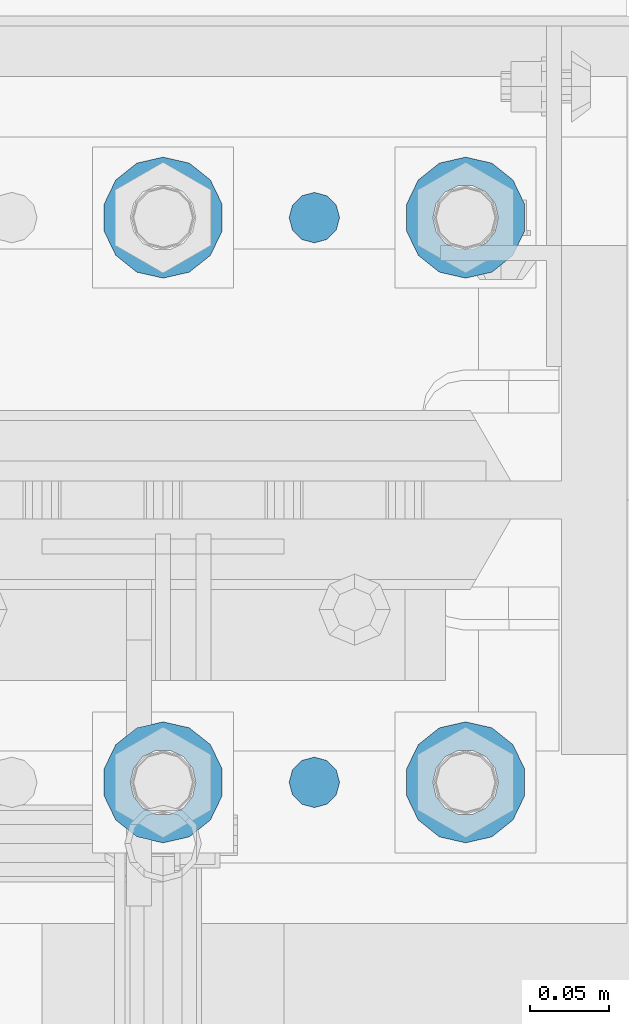
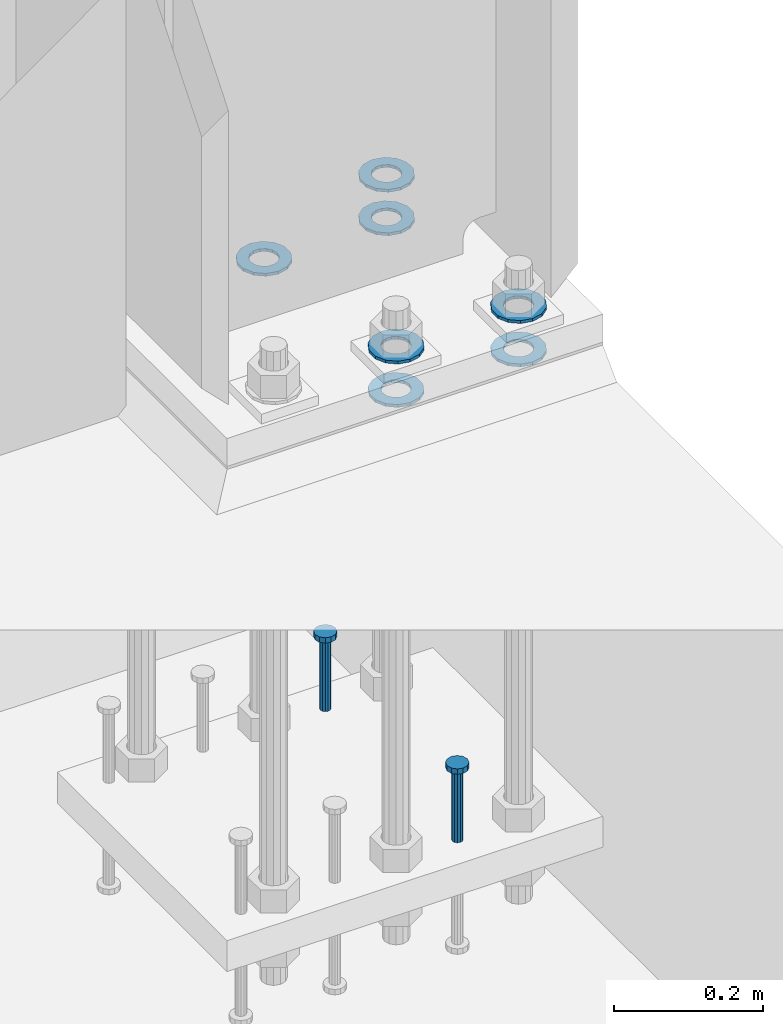
# One storey, part 859 of 1876: 9 columns, 1 element without a shape of its own.
"""IFC2X3 building model written with IfcOpenShell, lengths in millimetres."""

from ifc_helpers import new_model, si_unit, frame, origin_with_axes, place, context, subcontext, project, spatial, faceted_brep, material, type_object, element, aggregate, save


model = new_model("IFC2X3")

# Units and contexts
model_context = context("Model", 3, precision=1e-05, world=origin_with_axes())
body_context = subcontext(model_context, "Body", "Model", "MODEL_VIEW")
ifc_project = project(units=[si_unit("LENGTHUNIT", "METRE", prefix="MILLI"), si_unit("AREAUNIT", "SQUARE_METRE"), si_unit("VOLUMEUNIT", "CUBIC_METRE"), si_unit("MASSUNIT", "GRAM", prefix="KILO"), si_unit("TIMEUNIT", "SECOND"), si_unit("PLANEANGLEUNIT", "RADIAN"), si_unit("SOLIDANGLEUNIT", "STERADIAN"), si_unit("THERMODYNAMICTEMPERATUREUNIT", "DEGREE_CELSIUS"), si_unit("LUMINOUSINTENSITYUNIT", "LUMEN")], contexts=[model_context])

# Site, building, storey
site_placement = place(None, origin_with_axes())
site = spatial("IfcSite", under=ifc_project, at=site_placement, CompositionType="ELEMENT")
building_placement = place(site_placement, origin_with_axes())
building = spatial("IfcBuilding", under=site, at=building_placement, Name="Undefined", CompositionType="ELEMENT")
storey_placement = place(building_placement, origin_with_axes())
storey = spatial("IfcBuildingStorey", under=building, at=storey_placement, Name="Undefined", CompositionType="ELEMENT", Elevation=0.0)

# Assembly, columns
assembly_placement = place(storey_placement, origin_with_axes())
assembly = element("IfcElementAssembly", 1, at=assembly_placement, inside=storey, Name="TEMPLATE", AssemblyPlace="NOTDEFINED", PredefinedType="RIGID_FRAME")
ifc_material_1 = material(Name="STEEL/F436")
column_type_1 = type_object("IfcColumnType", Name="1-1/2_WASHER", PredefinedType="NOTDEFINED")
column_1_placement = place(assembly_placement, frame((7810.5, 13538.2, 38.1), z_axis=(1.0, 0.0, 0.0), x_axis=(0.0, 0.0, -1.0)))
column_1 = element("IfcColumn", 2, at=column_1_placement, type_object=column_type_1, material=ifc_material_1, Name="WASHER", ObjectType="1-1/2_WASHER", context=body_context, shape_type="Brep", body=[
    faceted_brep([(0.0, -38.0999984741211, 0.0), (0.0, -34.3269124923136, -16.5309697983251), (4.7625, -34.3269124923136, -16.5309697983251), (4.7625, -38.0999984741211, 0.0), (0.0, -23.7549604994474, -29.787778289052), (4.7625, -23.7549604994474, -29.787778289052), (0.0, -8.4780472441962, -37.1447519665058), (4.7625, -8.4780472441962, -37.1447519665058), (0.0, 8.4780472441962, -37.1447519665058), (4.7625, 8.4780472441962, -37.1447519665058), (0.0, 23.7549604994474, -29.787778289052), (4.7625, 23.7549604994474, -29.787778289052), (0.0, 34.3269124923136, -16.5309697983251), (4.7625, 34.3269124923136, -16.5309697983251), (0.0, 38.0999984741211, 0.0), (4.7625, 38.0999984741211, 0.0), (0.0, 34.3269124923136, 16.5309697983251), (4.7625, 34.3269124923136, 16.5309697983251), (0.0, 23.7549604994474, 29.787778289052), (4.7625, 23.7549604994474, 29.787778289052), (0.0, 8.4780472441962, 37.1447519665058), (4.7625, 8.4780472441962, 37.1447519665058), (0.0, -8.4780472441962, 37.1447519665058), (4.7625, -8.4780472441962, 37.1447519665058), (0.0, -23.7549604994474, 29.787778289052), (4.7625, -23.7549604994474, 29.787778289052), (0.0, -34.3269124923136, 16.5309697983251), (4.7625, -34.3269124923136, 16.5309697983251), (0.0, 0.0, 20.6399993896484), (0.0, 8.95536011056538, 18.5959968835978), (4.7625, 8.95536011056538, 18.595996883598), (4.7625, 0.0, 20.6399993896484), (0.0, 16.1370013209489, 12.8688291298158), (4.7625, 16.1370013209489, 12.8688291298162), (0.0, 20.1225115123834, 4.59283194104228), (4.7625, 20.1225115123834, 4.59283194104222), (0.0, 20.1225115123834, -4.59283194104228), (4.7625, 20.1225115123834, -4.59283194104242), (0.0, 16.1370013209489, -12.8688291298167), (4.7625, 16.1370013209489, -12.8688291298163), (0.0, 8.95536011056538, -18.5959968835978), (4.7625, 8.95536011056538, -18.5959968835982), (0.0, 0.0, -20.6399993896484), (4.7625, 0.0, -20.6399993896484), (0.0, -8.95536011056538, -18.5959968835978), (4.7625, -8.95536011056538, -18.595996883598), (0.0, -16.1370013209489, -12.8688291298158), (4.7625, -16.1370013209489, -12.8688291298162), (0.0, -20.1225115123834, -4.59283194104228), (4.7625, -20.1225115123834, -4.59283194104222), (0.0, -20.1225115123834, 4.59283194104228), (4.7625, -20.1225115123834, 4.59283194104242), (0.0, -16.1370013209489, 12.8688291298167), (4.7625, -16.1370013209489, 12.8688291298163), (0.0, -8.95536011056538, 18.5959968835978), (4.7625, -8.95536011056538, 18.5959968835982)], [[[0, 1, 2, 3]], [[1, 4, 5, 2]], [[4, 6, 7, 5]], [[6, 8, 9, 7]], [[8, 10, 11, 9]], [[10, 12, 13, 11]], [[12, 14, 15, 13]], [[14, 16, 17, 15]], [[16, 18, 19, 17]], [[18, 20, 21, 19]], [[20, 22, 23, 21]], [[22, 24, 25, 23]], [[24, 26, 27, 25]], [[26, 0, 3, 27]], [[28, 29, 30, 31]], [[29, 32, 33, 30]], [[32, 34, 35, 33]], [[34, 36, 37, 35]], [[36, 38, 39, 37]], [[38, 40, 41, 39]], [[40, 42, 43, 41]], [[42, 44, 45, 43]], [[44, 46, 47, 45]], [[46, 48, 49, 47]], [[48, 50, 51, 49]], [[50, 52, 53, 51]], [[52, 54, 55, 53]], [[54, 28, 31, 55]], [[5, 7, 9, 11, 13, 15, 17, 19, 21, 23, 25, 27, 3, 2], [33, 35, 37, 39, 41, 43, 45, 47, 49, 51, 53, 55, 31, 30]], [[26, 24, 22, 20, 18, 16, 14, 12, 10, 8, 6, 4, 1, 0], [54, 52, 50, 48, 46, 44, 42, 40, 38, 36, 34, 32, 29, 28]]]),
])
column_2_placement = place(assembly_placement, frame((7810.5, 13893.8, 38.1), z_axis=(-1.0, 0.0, 0.0), x_axis=(0.0, 0.0, -1.0)))
column_2 = element("IfcColumn", 3, at=column_2_placement, type_object=column_type_1, material=ifc_material_1, Name="WASHER", ObjectType="1-1/2_WASHER", context=body_context, shape_type="Brep", body=[
    faceted_brep([(0.0, -38.0999984741211, 0.0), (0.0, -34.3269124923136, -16.5309697983251), (4.7625, -34.3269124923136, -16.5309697983251), (4.7625, -38.0999984741211, 0.0), (0.0, -23.7549604994474, -29.787778289052), (4.7625, -23.7549604994474, -29.787778289052), (0.0, -8.4780472441962, -37.1447519665058), (4.7625, -8.4780472441962, -37.1447519665058), (0.0, 8.4780472441962, -37.1447519665058), (4.7625, 8.4780472441962, -37.1447519665058), (0.0, 23.7549604994474, -29.787778289052), (4.7625, 23.7549604994474, -29.787778289052), (0.0, 34.3269124923136, -16.5309697983251), (4.7625, 34.3269124923136, -16.5309697983251), (0.0, 38.0999984741211, 0.0), (4.7625, 38.0999984741211, 0.0), (0.0, 34.3269124923136, 16.5309697983251), (4.7625, 34.3269124923136, 16.5309697983251), (0.0, 23.7549604994474, 29.787778289052), (4.7625, 23.7549604994474, 29.787778289052), (0.0, 8.4780472441962, 37.1447519665058), (4.7625, 8.4780472441962, 37.1447519665058), (0.0, -8.4780472441962, 37.1447519665058), (4.7625, -8.4780472441962, 37.1447519665058), (0.0, -23.7549604994474, 29.787778289052), (4.7625, -23.7549604994474, 29.787778289052), (0.0, -34.3269124923136, 16.5309697983251), (4.7625, -34.3269124923136, 16.5309697983251), (0.0, 0.0, 20.6399993896484), (0.0, 8.95536011056538, 18.5959968835978), (4.7625, 8.95536011056538, 18.595996883598), (4.7625, 0.0, 20.6399993896484), (0.0, 16.1370013209489, 12.8688291298158), (4.7625, 16.1370013209489, 12.8688291298162), (0.0, 20.1225115123834, 4.59283194104228), (4.7625, 20.1225115123834, 4.59283194104222), (0.0, 20.1225115123834, -4.59283194104228), (4.7625, 20.1225115123834, -4.59283194104242), (0.0, 16.1370013209489, -12.8688291298167), (4.7625, 16.1370013209489, -12.8688291298163), (0.0, 8.95536011056538, -18.5959968835978), (4.7625, 8.95536011056538, -18.5959968835982), (0.0, 0.0, -20.6399993896484), (4.7625, 0.0, -20.6399993896484), (0.0, -8.95536011056538, -18.5959968835978), (4.7625, -8.95536011056538, -18.595996883598), (0.0, -16.1370013209489, -12.8688291298158), (4.7625, -16.1370013209489, -12.8688291298162), (0.0, -20.1225115123834, -4.59283194104228), (4.7625, -20.1225115123834, -4.59283194104222), (0.0, -20.1225115123834, 4.59283194104228), (4.7625, -20.1225115123834, 4.59283194104242), (0.0, -16.1370013209489, 12.8688291298167), (4.7625, -16.1370013209489, 12.8688291298163), (0.0, -8.95536011056538, 18.5959968835978), (4.7625, -8.95536011056538, 18.5959968835982)], [[[0, 1, 2, 3]], [[1, 4, 5, 2]], [[4, 6, 7, 5]], [[6, 8, 9, 7]], [[8, 10, 11, 9]], [[10, 12, 13, 11]], [[12, 14, 15, 13]], [[14, 16, 17, 15]], [[16, 18, 19, 17]], [[18, 20, 21, 19]], [[20, 22, 23, 21]], [[22, 24, 25, 23]], [[24, 26, 27, 25]], [[26, 0, 3, 27]], [[28, 29, 30, 31]], [[29, 32, 33, 30]], [[32, 34, 35, 33]], [[34, 36, 37, 35]], [[36, 38, 39, 37]], [[38, 40, 41, 39]], [[40, 42, 43, 41]], [[42, 44, 45, 43]], [[44, 46, 47, 45]], [[46, 48, 49, 47]], [[48, 50, 51, 49]], [[50, 52, 53, 51]], [[52, 54, 55, 53]], [[54, 28, 31, 55]], [[5, 7, 9, 11, 13, 15, 17, 19, 21, 23, 25, 27, 3, 2], [33, 35, 37, 39, 41, 43, 45, 47, 49, 51, 53, 55, 31, 30]], [[26, 24, 22, 20, 18, 16, 14, 12, 10, 8, 6, 4, 1, 0], [54, 52, 50, 48, 46, 44, 42, 40, 38, 36, 34, 32, 29, 28]]]),
])
column_3_placement = place(assembly_placement, frame((7620.0, 13538.2, 38.1), z_axis=(1.0, 0.0, 0.0), x_axis=(0.0, 0.0, -1.0)))
column_3 = element("IfcColumn", 4, at=column_3_placement, type_object=column_type_1, material=ifc_material_1, Name="WASHER", ObjectType="1-1/2_WASHER", context=body_context, shape_type="Brep", body=[
    faceted_brep([(0.0, -38.0999984741211, 0.0), (0.0, -34.3269124923136, -16.5309697983251), (4.7625, -34.3269124923136, -16.5309697983251), (4.7625, -38.0999984741211, 0.0), (0.0, -23.7549604994474, -29.787778289052), (4.7625, -23.7549604994474, -29.787778289052), (0.0, -8.4780472441962, -37.1447519665058), (4.7625, -8.4780472441962, -37.1447519665058), (0.0, 8.4780472441962, -37.1447519665058), (4.7625, 8.4780472441962, -37.1447519665058), (0.0, 23.7549604994474, -29.787778289052), (4.7625, 23.7549604994474, -29.787778289052), (0.0, 34.3269124923136, -16.5309697983251), (4.7625, 34.3269124923136, -16.5309697983251), (0.0, 38.0999984741211, 0.0), (4.7625, 38.0999984741211, 0.0), (0.0, 34.3269124923136, 16.5309697983251), (4.7625, 34.3269124923136, 16.5309697983251), (0.0, 23.7549604994474, 29.787778289052), (4.7625, 23.7549604994474, 29.787778289052), (0.0, 8.4780472441962, 37.1447519665058), (4.7625, 8.4780472441962, 37.1447519665058), (0.0, -8.4780472441962, 37.1447519665058), (4.7625, -8.4780472441962, 37.1447519665058), (0.0, -23.7549604994474, 29.787778289052), (4.7625, -23.7549604994474, 29.787778289052), (0.0, -34.3269124923136, 16.5309697983251), (4.7625, -34.3269124923136, 16.5309697983251), (0.0, 0.0, 20.6399993896484), (0.0, 8.95536011056538, 18.5959968835978), (4.7625, 8.95536011056538, 18.595996883598), (4.7625, 0.0, 20.6399993896484), (0.0, 16.1370013209489, 12.8688291298158), (4.7625, 16.1370013209489, 12.8688291298162), (0.0, 20.1225115123834, 4.59283194104228), (4.7625, 20.1225115123834, 4.59283194104222), (0.0, 20.1225115123834, -4.59283194104228), (4.7625, 20.1225115123834, -4.59283194104242), (0.0, 16.1370013209489, -12.8688291298167), (4.7625, 16.1370013209489, -12.8688291298163), (0.0, 8.95536011056538, -18.5959968835978), (4.7625, 8.95536011056538, -18.5959968835982), (0.0, 0.0, -20.6399993896484), (4.7625, 0.0, -20.6399993896484), (0.0, -8.95536011056538, -18.5959968835978), (4.7625, -8.95536011056538, -18.595996883598), (0.0, -16.1370013209489, -12.8688291298158), (4.7625, -16.1370013209489, -12.8688291298162), (0.0, -20.1225115123834, -4.59283194104228), (4.7625, -20.1225115123834, -4.59283194104222), (0.0, -20.1225115123834, 4.59283194104228), (4.7625, -20.1225115123834, 4.59283194104242), (0.0, -16.1370013209489, 12.8688291298167), (4.7625, -16.1370013209489, 12.8688291298163), (0.0, -8.95536011056538, 18.5959968835978), (4.7625, -8.95536011056538, 18.5959968835982)], [[[0, 1, 2, 3]], [[1, 4, 5, 2]], [[4, 6, 7, 5]], [[6, 8, 9, 7]], [[8, 10, 11, 9]], [[10, 12, 13, 11]], [[12, 14, 15, 13]], [[14, 16, 17, 15]], [[16, 18, 19, 17]], [[18, 20, 21, 19]], [[20, 22, 23, 21]], [[22, 24, 25, 23]], [[24, 26, 27, 25]], [[26, 0, 3, 27]], [[28, 29, 30, 31]], [[29, 32, 33, 30]], [[32, 34, 35, 33]], [[34, 36, 37, 35]], [[36, 38, 39, 37]], [[38, 40, 41, 39]], [[40, 42, 43, 41]], [[42, 44, 45, 43]], [[44, 46, 47, 45]], [[46, 48, 49, 47]], [[48, 50, 51, 49]], [[50, 52, 53, 51]], [[52, 54, 55, 53]], [[54, 28, 31, 55]], [[5, 7, 9, 11, 13, 15, 17, 19, 21, 23, 25, 27, 3, 2], [33, 35, 37, 39, 41, 43, 45, 47, 49, 51, 53, 55, 31, 30]], [[26, 24, 22, 20, 18, 16, 14, 12, 10, 8, 6, 4, 1, 0], [54, 52, 50, 48, 46, 44, 42, 40, 38, 36, 34, 32, 29, 28]]]),
])
column_4_placement = place(assembly_placement, frame((7620.0, 13893.8, 38.1), z_axis=(-1.0, 0.0, 0.0), x_axis=(0.0, 0.0, -1.0)))
column_4 = element("IfcColumn", 5, at=column_4_placement, type_object=column_type_1, material=ifc_material_1, Name="WASHER", ObjectType="1-1/2_WASHER", context=body_context, shape_type="Brep", body=[
    faceted_brep([(0.0, -38.0999984741211, 0.0), (0.0, -34.3269124923136, -16.5309697983251), (4.7625, -34.3269124923136, -16.5309697983251), (4.7625, -38.0999984741211, 0.0), (0.0, -23.7549604994474, -29.787778289052), (4.7625, -23.7549604994474, -29.787778289052), (0.0, -8.4780472441962, -37.1447519665058), (4.7625, -8.4780472441962, -37.1447519665058), (0.0, 8.4780472441962, -37.1447519665058), (4.7625, 8.4780472441962, -37.1447519665058), (0.0, 23.7549604994474, -29.787778289052), (4.7625, 23.7549604994474, -29.787778289052), (0.0, 34.3269124923136, -16.5309697983251), (4.7625, 34.3269124923136, -16.5309697983251), (0.0, 38.0999984741211, 0.0), (4.7625, 38.0999984741211, 0.0), (0.0, 34.3269124923136, 16.5309697983251), (4.7625, 34.3269124923136, 16.5309697983251), (0.0, 23.7549604994474, 29.787778289052), (4.7625, 23.7549604994474, 29.787778289052), (0.0, 8.4780472441962, 37.1447519665058), (4.7625, 8.4780472441962, 37.1447519665058), (0.0, -8.4780472441962, 37.1447519665058), (4.7625, -8.4780472441962, 37.1447519665058), (0.0, -23.7549604994474, 29.787778289052), (4.7625, -23.7549604994474, 29.787778289052), (0.0, -34.3269124923136, 16.5309697983251), (4.7625, -34.3269124923136, 16.5309697983251), (0.0, 0.0, 20.6399993896484), (0.0, 8.95536011056538, 18.5959968835978), (4.7625, 8.95536011056538, 18.595996883598), (4.7625, 0.0, 20.6399993896484), (0.0, 16.1370013209489, 12.8688291298158), (4.7625, 16.1370013209489, 12.8688291298162), (0.0, 20.1225115123834, 4.59283194104228), (4.7625, 20.1225115123834, 4.59283194104222), (0.0, 20.1225115123834, -4.59283194104228), (4.7625, 20.1225115123834, -4.59283194104242), (0.0, 16.1370013209489, -12.8688291298167), (4.7625, 16.1370013209489, -12.8688291298163), (0.0, 8.95536011056538, -18.5959968835978), (4.7625, 8.95536011056538, -18.5959968835982), (0.0, 0.0, -20.6399993896484), (4.7625, 0.0, -20.6399993896484), (0.0, -8.95536011056538, -18.5959968835978), (4.7625, -8.95536011056538, -18.595996883598), (0.0, -16.1370013209489, -12.8688291298158), (4.7625, -16.1370013209489, -12.8688291298162), (0.0, -20.1225115123834, -4.59283194104228), (4.7625, -20.1225115123834, -4.59283194104222), (0.0, -20.1225115123834, 4.59283194104228), (4.7625, -20.1225115123834, 4.59283194104242), (0.0, -16.1370013209489, 12.8688291298167), (4.7625, -16.1370013209489, 12.8688291298163), (0.0, -8.95536011056538, 18.5959968835978), (4.7625, -8.95536011056538, 18.5959968835982)], [[[0, 1, 2, 3]], [[1, 4, 5, 2]], [[4, 6, 7, 5]], [[6, 8, 9, 7]], [[8, 10, 11, 9]], [[10, 12, 13, 11]], [[12, 14, 15, 13]], [[14, 16, 17, 15]], [[16, 18, 19, 17]], [[18, 20, 21, 19]], [[20, 22, 23, 21]], [[22, 24, 25, 23]], [[24, 26, 27, 25]], [[26, 0, 3, 27]], [[28, 29, 30, 31]], [[29, 32, 33, 30]], [[32, 34, 35, 33]], [[34, 36, 37, 35]], [[36, 38, 39, 37]], [[38, 40, 41, 39]], [[40, 42, 43, 41]], [[42, 44, 45, 43]], [[44, 46, 47, 45]], [[46, 48, 49, 47]], [[48, 50, 51, 49]], [[50, 52, 53, 51]], [[52, 54, 55, 53]], [[54, 28, 31, 55]], [[5, 7, 9, 11, 13, 15, 17, 19, 21, 23, 25, 27, 3, 2], [33, 35, 37, 39, 41, 43, 45, 47, 49, 51, 53, 55, 31, 30]], [[26, 24, 22, 20, 18, 16, 14, 12, 10, 8, 6, 4, 1, 0], [54, 52, 50, 48, 46, 44, 42, 40, 38, 36, 34, 32, 29, 28]]]),
])
column_5_placement = place(assembly_placement, frame((7810.5, 13538.2, 109.5375), z_axis=(1.0, 0.0, 0.0), x_axis=(0.0, 0.0, -1.0)))
column_5 = element("IfcColumn", 6, at=column_5_placement, type_object=column_type_1, material=ifc_material_1, Name="WASHER", ObjectType="1-1/2_WASHER", context=body_context, shape_type="Brep", body=[
    faceted_brep([(0.0, -38.0999984741211, 0.0), (0.0, -34.3269124923136, -16.5309697983251), (4.7625, -34.3269124923136, -16.5309697983251), (4.7625, -38.0999984741211, 0.0), (0.0, -23.7549604994474, -29.787778289052), (4.7625, -23.7549604994474, -29.787778289052), (0.0, -8.4780472441962, -37.1447519665058), (4.7625, -8.4780472441962, -37.1447519665058), (0.0, 8.4780472441962, -37.1447519665058), (4.7625, 8.4780472441962, -37.1447519665058), (0.0, 23.7549604994474, -29.787778289052), (4.7625, 23.7549604994474, -29.787778289052), (0.0, 34.3269124923136, -16.5309697983251), (4.7625, 34.3269124923136, -16.5309697983251), (0.0, 38.0999984741211, 0.0), (4.7625, 38.0999984741211, 0.0), (0.0, 34.3269124923136, 16.5309697983251), (4.7625, 34.3269124923136, 16.5309697983251), (0.0, 23.7549604994474, 29.787778289052), (4.7625, 23.7549604994474, 29.787778289052), (0.0, 8.4780472441962, 37.1447519665058), (4.7625, 8.4780472441962, 37.1447519665058), (0.0, -8.4780472441962, 37.1447519665058), (4.7625, -8.4780472441962, 37.1447519665058), (0.0, -23.7549604994474, 29.787778289052), (4.7625, -23.7549604994474, 29.787778289052), (0.0, -34.3269124923136, 16.5309697983251), (4.7625, -34.3269124923136, 16.5309697983251), (0.0, 0.0, 20.6399993896484), (0.0, 8.95536011056538, 18.5959968835978), (4.7625, 8.95536011056538, 18.595996883598), (4.7625, 0.0, 20.6399993896484), (0.0, 16.1370013209489, 12.8688291298158), (4.7625, 16.1370013209489, 12.8688291298162), (0.0, 20.1225115123834, 4.59283194104228), (4.7625, 20.1225115123834, 4.59283194104222), (0.0, 20.1225115123834, -4.59283194104228), (4.7625, 20.1225115123834, -4.59283194104242), (0.0, 16.1370013209489, -12.8688291298167), (4.7625, 16.1370013209489, -12.8688291298163), (0.0, 8.95536011056538, -18.5959968835978), (4.7625, 8.95536011056538, -18.5959968835982), (0.0, 0.0, -20.6399993896484), (4.7625, 0.0, -20.6399993896484), (0.0, -8.95536011056538, -18.5959968835978), (4.7625, -8.95536011056538, -18.595996883598), (0.0, -16.1370013209489, -12.8688291298158), (4.7625, -16.1370013209489, -12.8688291298162), (0.0, -20.1225115123834, -4.59283194104228), (4.7625, -20.1225115123834, -4.59283194104222), (0.0, -20.1225115123834, 4.59283194104228), (4.7625, -20.1225115123834, 4.59283194104242), (0.0, -16.1370013209489, 12.8688291298167), (4.7625, -16.1370013209489, 12.8688291298163), (0.0, -8.95536011056538, 18.5959968835978), (4.7625, -8.95536011056538, 18.5959968835982)], [[[0, 1, 2, 3]], [[1, 4, 5, 2]], [[4, 6, 7, 5]], [[6, 8, 9, 7]], [[8, 10, 11, 9]], [[10, 12, 13, 11]], [[12, 14, 15, 13]], [[14, 16, 17, 15]], [[16, 18, 19, 17]], [[18, 20, 21, 19]], [[20, 22, 23, 21]], [[22, 24, 25, 23]], [[24, 26, 27, 25]], [[26, 0, 3, 27]], [[28, 29, 30, 31]], [[29, 32, 33, 30]], [[32, 34, 35, 33]], [[34, 36, 37, 35]], [[36, 38, 39, 37]], [[38, 40, 41, 39]], [[40, 42, 43, 41]], [[42, 44, 45, 43]], [[44, 46, 47, 45]], [[46, 48, 49, 47]], [[48, 50, 51, 49]], [[50, 52, 53, 51]], [[52, 54, 55, 53]], [[54, 28, 31, 55]], [[5, 7, 9, 11, 13, 15, 17, 19, 21, 23, 25, 27, 3, 2], [33, 35, 37, 39, 41, 43, 45, 47, 49, 51, 53, 55, 31, 30]], [[26, 24, 22, 20, 18, 16, 14, 12, 10, 8, 6, 4, 1, 0], [54, 52, 50, 48, 46, 44, 42, 40, 38, 36, 34, 32, 29, 28]]]),
])
column_6_placement = place(assembly_placement, frame((7810.5, 13893.8, 109.5375), z_axis=(-1.0, 0.0, 0.0), x_axis=(0.0, 0.0, -1.0)))
column_6 = element("IfcColumn", 7, at=column_6_placement, type_object=column_type_1, material=ifc_material_1, Name="WASHER", ObjectType="1-1/2_WASHER", context=body_context, shape_type="Brep", body=[
    faceted_brep([(0.0, -38.0999984741211, 0.0), (0.0, -34.3269124923136, -16.5309697983251), (4.7625, -34.3269124923136, -16.5309697983251), (4.7625, -38.0999984741211, 0.0), (0.0, -23.7549604994474, -29.787778289052), (4.7625, -23.7549604994474, -29.787778289052), (0.0, -8.4780472441962, -37.1447519665058), (4.7625, -8.4780472441962, -37.1447519665058), (0.0, 8.4780472441962, -37.1447519665058), (4.7625, 8.4780472441962, -37.1447519665058), (0.0, 23.7549604994474, -29.787778289052), (4.7625, 23.7549604994474, -29.787778289052), (0.0, 34.3269124923136, -16.5309697983251), (4.7625, 34.3269124923136, -16.5309697983251), (0.0, 38.0999984741211, 0.0), (4.7625, 38.0999984741211, 0.0), (0.0, 34.3269124923136, 16.5309697983251), (4.7625, 34.3269124923136, 16.5309697983251), (0.0, 23.7549604994474, 29.787778289052), (4.7625, 23.7549604994474, 29.787778289052), (0.0, 8.4780472441962, 37.1447519665058), (4.7625, 8.4780472441962, 37.1447519665058), (0.0, -8.4780472441962, 37.1447519665058), (4.7625, -8.4780472441962, 37.1447519665058), (0.0, -23.7549604994474, 29.787778289052), (4.7625, -23.7549604994474, 29.787778289052), (0.0, -34.3269124923136, 16.5309697983251), (4.7625, -34.3269124923136, 16.5309697983251), (0.0, 0.0, 20.6399993896484), (0.0, 8.95536011056538, 18.5959968835978), (4.7625, 8.95536011056538, 18.595996883598), (4.7625, 0.0, 20.6399993896484), (0.0, 16.1370013209489, 12.8688291298158), (4.7625, 16.1370013209489, 12.8688291298162), (0.0, 20.1225115123834, 4.59283194104228), (4.7625, 20.1225115123834, 4.59283194104222), (0.0, 20.1225115123834, -4.59283194104228), (4.7625, 20.1225115123834, -4.59283194104242), (0.0, 16.1370013209489, -12.8688291298167), (4.7625, 16.1370013209489, -12.8688291298163), (0.0, 8.95536011056538, -18.5959968835978), (4.7625, 8.95536011056538, -18.5959968835982), (0.0, 0.0, -20.6399993896484), (4.7625, 0.0, -20.6399993896484), (0.0, -8.95536011056538, -18.5959968835978), (4.7625, -8.95536011056538, -18.595996883598), (0.0, -16.1370013209489, -12.8688291298158), (4.7625, -16.1370013209489, -12.8688291298162), (0.0, -20.1225115123834, -4.59283194104228), (4.7625, -20.1225115123834, -4.59283194104222), (0.0, -20.1225115123834, 4.59283194104228), (4.7625, -20.1225115123834, 4.59283194104242), (0.0, -16.1370013209489, 12.8688291298167), (4.7625, -16.1370013209489, 12.8688291298163), (0.0, -8.95536011056538, 18.5959968835978), (4.7625, -8.95536011056538, 18.5959968835982)], [[[0, 1, 2, 3]], [[1, 4, 5, 2]], [[4, 6, 7, 5]], [[6, 8, 9, 7]], [[8, 10, 11, 9]], [[10, 12, 13, 11]], [[12, 14, 15, 13]], [[14, 16, 17, 15]], [[16, 18, 19, 17]], [[18, 20, 21, 19]], [[20, 22, 23, 21]], [[22, 24, 25, 23]], [[24, 26, 27, 25]], [[26, 0, 3, 27]], [[28, 29, 30, 31]], [[29, 32, 33, 30]], [[32, 34, 35, 33]], [[34, 36, 37, 35]], [[36, 38, 39, 37]], [[38, 40, 41, 39]], [[40, 42, 43, 41]], [[42, 44, 45, 43]], [[44, 46, 47, 45]], [[46, 48, 49, 47]], [[48, 50, 51, 49]], [[50, 52, 53, 51]], [[52, 54, 55, 53]], [[54, 28, 31, 55]], [[5, 7, 9, 11, 13, 15, 17, 19, 21, 23, 25, 27, 3, 2], [33, 35, 37, 39, 41, 43, 45, 47, 49, 51, 53, 55, 31, 30]], [[26, 24, 22, 20, 18, 16, 14, 12, 10, 8, 6, 4, 1, 0], [54, 52, 50, 48, 46, 44, 42, 40, 38, 36, 34, 32, 29, 28]]]),
])
column_7_placement = place(assembly_placement, frame((7620.0, 13538.2, 109.5375), z_axis=(1.0, 0.0, 0.0), x_axis=(0.0, 0.0, -1.0)))
column_7 = element("IfcColumn", 8, at=column_7_placement, type_object=column_type_1, material=ifc_material_1, Name="WASHER", ObjectType="1-1/2_WASHER", context=body_context, shape_type="Brep", body=[
    faceted_brep([(0.0, -38.0999984741211, 0.0), (0.0, -34.3269124923136, -16.5309697983251), (4.7625, -34.3269124923136, -16.5309697983251), (4.7625, -38.0999984741211, 0.0), (0.0, -23.7549604994474, -29.787778289052), (4.7625, -23.7549604994474, -29.787778289052), (0.0, -8.4780472441962, -37.1447519665058), (4.7625, -8.4780472441962, -37.1447519665058), (0.0, 8.4780472441962, -37.1447519665058), (4.7625, 8.4780472441962, -37.1447519665058), (0.0, 23.7549604994474, -29.787778289052), (4.7625, 23.7549604994474, -29.787778289052), (0.0, 34.3269124923136, -16.5309697983251), (4.7625, 34.3269124923136, -16.5309697983251), (0.0, 38.0999984741211, 0.0), (4.7625, 38.0999984741211, 0.0), (0.0, 34.3269124923136, 16.5309697983251), (4.7625, 34.3269124923136, 16.5309697983251), (0.0, 23.7549604994474, 29.787778289052), (4.7625, 23.7549604994474, 29.787778289052), (0.0, 8.4780472441962, 37.1447519665058), (4.7625, 8.4780472441962, 37.1447519665058), (0.0, -8.4780472441962, 37.1447519665058), (4.7625, -8.4780472441962, 37.1447519665058), (0.0, -23.7549604994474, 29.787778289052), (4.7625, -23.7549604994474, 29.787778289052), (0.0, -34.3269124923136, 16.5309697983251), (4.7625, -34.3269124923136, 16.5309697983251), (0.0, 0.0, 20.6399993896484), (0.0, 8.95536011056538, 18.5959968835978), (4.7625, 8.95536011056538, 18.595996883598), (4.7625, 0.0, 20.6399993896484), (0.0, 16.1370013209489, 12.8688291298158), (4.7625, 16.1370013209489, 12.8688291298162), (0.0, 20.1225115123834, 4.59283194104228), (4.7625, 20.1225115123834, 4.59283194104222), (0.0, 20.1225115123834, -4.59283194104228), (4.7625, 20.1225115123834, -4.59283194104242), (0.0, 16.1370013209489, -12.8688291298167), (4.7625, 16.1370013209489, -12.8688291298163), (0.0, 8.95536011056538, -18.5959968835978), (4.7625, 8.95536011056538, -18.5959968835982), (0.0, 0.0, -20.6399993896484), (4.7625, 0.0, -20.6399993896484), (0.0, -8.95536011056538, -18.5959968835978), (4.7625, -8.95536011056538, -18.595996883598), (0.0, -16.1370013209489, -12.8688291298158), (4.7625, -16.1370013209489, -12.8688291298162), (0.0, -20.1225115123834, -4.59283194104228), (4.7625, -20.1225115123834, -4.59283194104222), (0.0, -20.1225115123834, 4.59283194104228), (4.7625, -20.1225115123834, 4.59283194104242), (0.0, -16.1370013209489, 12.8688291298167), (4.7625, -16.1370013209489, 12.8688291298163), (0.0, -8.95536011056538, 18.5959968835978), (4.7625, -8.95536011056538, 18.5959968835982)], [[[0, 1, 2, 3]], [[1, 4, 5, 2]], [[4, 6, 7, 5]], [[6, 8, 9, 7]], [[8, 10, 11, 9]], [[10, 12, 13, 11]], [[12, 14, 15, 13]], [[14, 16, 17, 15]], [[16, 18, 19, 17]], [[18, 20, 21, 19]], [[20, 22, 23, 21]], [[22, 24, 25, 23]], [[24, 26, 27, 25]], [[26, 0, 3, 27]], [[28, 29, 30, 31]], [[29, 32, 33, 30]], [[32, 34, 35, 33]], [[34, 36, 37, 35]], [[36, 38, 39, 37]], [[38, 40, 41, 39]], [[40, 42, 43, 41]], [[42, 44, 45, 43]], [[44, 46, 47, 45]], [[46, 48, 49, 47]], [[48, 50, 51, 49]], [[50, 52, 53, 51]], [[52, 54, 55, 53]], [[54, 28, 31, 55]], [[5, 7, 9, 11, 13, 15, 17, 19, 21, 23, 25, 27, 3, 2], [33, 35, 37, 39, 41, 43, 45, 47, 49, 51, 53, 55, 31, 30]], [[26, 24, 22, 20, 18, 16, 14, 12, 10, 8, 6, 4, 1, 0], [54, 52, 50, 48, 46, 44, 42, 40, 38, 36, 34, 32, 29, 28]]]),
])
ifc_material_2 = material(Name="STEEL/A108")
column_type_2 = type_object("IfcColumnType", Name="5/8-DIA_HEADED ANCHOR STUD", PredefinedType="NOTDEFINED")
column_8_placement = place(assembly_placement, frame((7715.25, 13893.8, -736.6), z_axis=(1.0, 0.0, 0.0), x_axis=(0.0, 0.0, 1.0)))
column_8 = element("IfcColumn", 9, at=column_8_placement, type_object=column_type_2, material=ifc_material_2, Name="HEADED ANCHOR STUD", ObjectType="5/8-DIA_HEADED ANCHOR STUD", context=body_context, shape_type="Brep", body=[
    faceted_brep([(0.0, -7.94000005722046, 0.0), (0.0, -6.86999988555908, -3.97000002861023), (116.84, -6.86999988555908, -3.97000002861023), (116.84, -7.94000005722046, 0.0), (0.0, -3.97000002861023, -6.86999988555908), (116.84, -3.97000002861023, -6.86999988555908), (0.0, 0.0, -7.94000005722046), (116.84, 0.0, -7.94000005722046), (0.0, 3.97000002861023, -6.86999988555908), (116.84, 3.97000002861023, -6.86999988555908), (0.0, 6.86999988555908, -3.97000002861023), (116.84, 6.86999988555908, -3.97000002861023), (0.0, 7.94000005722046, 0.0), (116.84, 7.94000005722046, 0.0), (0.0, 6.86999988555908, 3.97000002861023), (116.84, 6.86999988555908, 3.97000002861023), (0.0, 3.97000002861023, 6.86999988555908), (116.84, 3.97000002861023, 6.86999988555908), (0.0, 0.0, 7.94000005722046), (116.84, 0.0, 7.94000005722046), (0.0, -3.97000002861023, 6.86999988555908), (116.84, -3.97000002861023, 6.86999988555908), (0.0, -6.86999988555908, 3.97000002861023), (116.84, -6.86999988555908, 3.97000002861023), (118.11, -13.75, -7.94000005722046), (118.11, -15.8800001144409, 0.0), (118.11, -7.94000005722046, -13.75), (118.11, 0.0, -15.8800001144409), (118.11, 7.94000005722046, -13.75), (118.11, 13.75, -7.94000005722046), (118.11, 15.8800001144409, 0.0), (118.11, 13.75, 7.94000005722046), (118.11, 7.94000005722046, 13.75), (118.11, 0.0, 15.8800001144409), (118.11, -7.94000005722046, 13.75), (118.11, -13.75, 7.94000005722046), (127.0, -13.75, -7.94000005722046), (127.0, -15.8800001144409, 0.0), (127.0, -7.94000005722046, -13.75), (127.0, 0.0, -15.8800001144409), (127.0, 7.94000005722046, -13.75), (127.0, 13.75, -7.94000005722046), (127.0, 15.8800001144409, 0.0), (127.0, 13.75, 7.94000005722046), (127.0, 7.94000005722046, 13.75), (127.0, 0.0, 15.8800001144409), (127.0, -7.94000005722046, 13.75), (127.0, -13.75, 7.94000005722046)], [[[0, 1, 2, 3]], [[1, 4, 5, 2]], [[4, 6, 7, 5]], [[6, 8, 9, 7]], [[8, 10, 11, 9]], [[10, 12, 13, 11]], [[12, 14, 15, 13]], [[14, 16, 17, 15]], [[16, 18, 19, 17]], [[18, 20, 21, 19]], [[20, 22, 23, 21]], [[22, 0, 3, 23]], [[22, 20, 18, 16, 14, 12, 10, 8, 6, 4, 1, 0]], [[3, 2, 24, 25]], [[2, 5, 26, 24]], [[5, 7, 27, 26]], [[7, 9, 28, 27]], [[9, 11, 29, 28]], [[11, 13, 30, 29]], [[13, 15, 31, 30]], [[15, 17, 32, 31]], [[17, 19, 33, 32]], [[19, 21, 34, 33]], [[21, 23, 35, 34]], [[23, 3, 25, 35]], [[25, 24, 36, 37]], [[24, 26, 38, 36]], [[26, 27, 39, 38]], [[27, 28, 40, 39]], [[28, 29, 41, 40]], [[29, 30, 42, 41]], [[30, 31, 43, 42]], [[31, 32, 44, 43]], [[32, 33, 45, 44]], [[33, 34, 46, 45]], [[34, 35, 47, 46]], [[35, 25, 37, 47]], [[38, 39, 40, 41, 42, 43, 44, 45, 46, 47, 37, 36]]]),
])
column_9_placement = place(assembly_placement, frame((7715.25, 13538.2, -736.6), z_axis=(1.0, 0.0, 0.0), x_axis=(0.0, 0.0, 1.0)))
column_9 = element("IfcColumn", 10, at=column_9_placement, type_object=column_type_2, material=ifc_material_2, Name="HEADED ANCHOR STUD", ObjectType="5/8-DIA_HEADED ANCHOR STUD", context=body_context, shape_type="Brep", body=[
    faceted_brep([(0.0, -7.94000005722046, 0.0), (0.0, -6.86999988555908, -3.97000002861023), (116.84, -6.86999988555908, -3.97000002861023), (116.84, -7.94000005722046, 0.0), (0.0, -3.97000002861023, -6.86999988555908), (116.84, -3.97000002861023, -6.86999988555908), (0.0, 0.0, -7.94000005722046), (116.84, 0.0, -7.94000005722046), (0.0, 3.97000002861023, -6.86999988555908), (116.84, 3.97000002861023, -6.86999988555908), (0.0, 6.86999988555908, -3.97000002861023), (116.84, 6.86999988555908, -3.97000002861023), (0.0, 7.94000005722046, 0.0), (116.84, 7.94000005722046, 0.0), (0.0, 6.86999988555908, 3.97000002861023), (116.84, 6.86999988555908, 3.97000002861023), (0.0, 3.97000002861023, 6.86999988555908), (116.84, 3.97000002861023, 6.86999988555908), (0.0, 0.0, 7.94000005722046), (116.84, 0.0, 7.94000005722046), (0.0, -3.97000002861023, 6.86999988555908), (116.84, -3.97000002861023, 6.86999988555908), (0.0, -6.86999988555908, 3.97000002861023), (116.84, -6.86999988555908, 3.97000002861023), (118.11, -13.75, -7.94000005722046), (118.11, -15.8800001144409, 0.0), (118.11, -7.94000005722046, -13.75), (118.11, 0.0, -15.8800001144409), (118.11, 7.94000005722046, -13.75), (118.11, 13.75, -7.94000005722046), (118.11, 15.8800001144409, 0.0), (118.11, 13.75, 7.94000005722046), (118.11, 7.94000005722046, 13.75), (118.11, 0.0, 15.8800001144409), (118.11, -7.94000005722046, 13.75), (118.11, -13.75, 7.94000005722046), (127.0, -13.75, -7.94000005722046), (127.0, -15.8800001144409, 0.0), (127.0, -7.94000005722046, -13.75), (127.0, 0.0, -15.8800001144409), (127.0, 7.94000005722046, -13.75), (127.0, 13.75, -7.94000005722046), (127.0, 15.8800001144409, 0.0), (127.0, 13.75, 7.94000005722046), (127.0, 7.94000005722046, 13.75), (127.0, 0.0, 15.8800001144409), (127.0, -7.94000005722046, 13.75), (127.0, -13.75, 7.94000005722046)], [[[0, 1, 2, 3]], [[1, 4, 5, 2]], [[4, 6, 7, 5]], [[6, 8, 9, 7]], [[8, 10, 11, 9]], [[10, 12, 13, 11]], [[12, 14, 15, 13]], [[14, 16, 17, 15]], [[16, 18, 19, 17]], [[18, 20, 21, 19]], [[20, 22, 23, 21]], [[22, 0, 3, 23]], [[22, 20, 18, 16, 14, 12, 10, 8, 6, 4, 1, 0]], [[3, 2, 24, 25]], [[2, 5, 26, 24]], [[5, 7, 27, 26]], [[7, 9, 28, 27]], [[9, 11, 29, 28]], [[11, 13, 30, 29]], [[13, 15, 31, 30]], [[15, 17, 32, 31]], [[17, 19, 33, 32]], [[19, 21, 34, 33]], [[21, 23, 35, 34]], [[23, 3, 25, 35]], [[25, 24, 36, 37]], [[24, 26, 38, 36]], [[26, 27, 39, 38]], [[27, 28, 40, 39]], [[28, 29, 41, 40]], [[29, 30, 42, 41]], [[30, 31, 43, 42]], [[31, 32, 44, 43]], [[32, 33, 45, 44]], [[33, 34, 46, 45]], [[34, 35, 47, 46]], [[35, 25, 37, 47]], [[38, 39, 40, 41, 42, 43, 44, 45, 46, 47, 37, 36]]]),
])
aggregate(assembly, [column_1, column_2, column_3, column_4, column_8, column_9, column_5, column_6, column_7])

save(model, "model.ifc")
